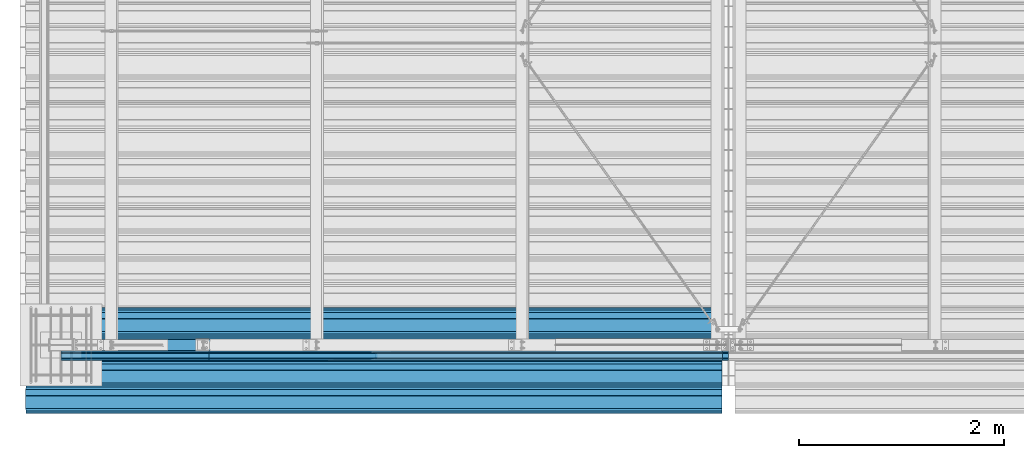
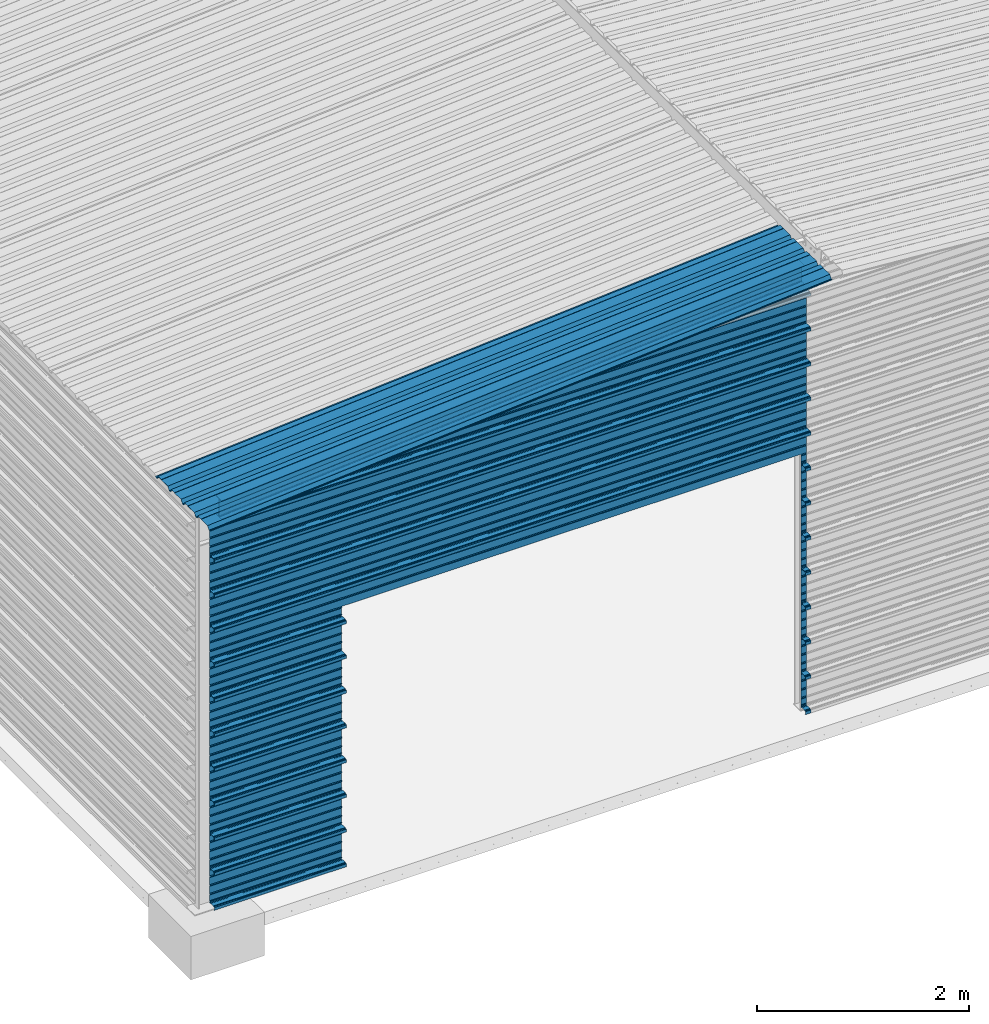
# One storey, part 4 of 70: 14 beams, 14 elements without a shape of their own.
"""IFC2X3 building model written with IfcOpenShell, lengths in millimetres."""

from ifc_helpers import new_model, si_unit, frame, origin_with_axes, origin_2d_with_axis, place, context, subcontext, project, spatial, polyline, i_section, outline, extrude, boolean, clip, halfspace, material, type_object, element, aggregate, save


model = new_model("IFC2X3")

# Units and contexts
model_context = context("Model", 3, precision=1e-05, world=origin_with_axes())
body_context = subcontext(model_context, "Body", "Model", "MODEL_VIEW")
ifc_project = project(units=[si_unit("LENGTHUNIT", "METRE", prefix="MILLI"), si_unit("AREAUNIT", "SQUARE_METRE"), si_unit("VOLUMEUNIT", "CUBIC_METRE"), si_unit("MASSUNIT", "GRAM", prefix="KILO"), si_unit("TIMEUNIT", "SECOND"), si_unit("PLANEANGLEUNIT", "RADIAN"), si_unit("SOLIDANGLEUNIT", "STERADIAN"), si_unit("THERMODYNAMICTEMPERATUREUNIT", "DEGREE_CELSIUS"), si_unit("LUMINOUSINTENSITYUNIT", "LUMEN")], contexts=[model_context])

# Site, building, storey
site_placement = place(None, origin_with_axes())
site = spatial("IfcSite", under=ifc_project, at=site_placement, CompositionType="ELEMENT")
building_placement = place(site_placement, origin_with_axes())
building = spatial("IfcBuilding", under=site, at=building_placement, Name="Undefined", CompositionType="ELEMENT")
storey_placement = place(building_placement, origin_with_axes())
storey = spatial("IfcBuildingStorey", under=building, at=storey_placement, Name="Undefined", CompositionType="ELEMENT", Elevation=0.0)

# Assembly, beam
assembly_1_placement = place(storey_placement, origin_with_axes())
assembly_1 = element("IfcElementAssembly", 1, at=assembly_1_placement, inside=storey, Name="Steel Assembly", AssemblyPlace="NOTDEFINED", PredefinedType="RIGID_FRAME")
ifc_material = material(Name="STEEL/S235JR")
beam_type_1 = type_object("IfcBeamType", Name="4.40", PredefinedType="NOTDEFINED")
beam_1_placement = place(assembly_1_placement, frame((6436.39248868039, -150.0, 5336.31760454388), z_axis=(0.0766964990376782, 0.0, -0.997054485489817), x_axis=(-0.997054485489818, 0.0, -0.0766964990376602)))
beam_1 = element("IfcBeam", 2, at=beam_1_placement, type_object=beam_type_1, material=ifc_material, ObjectType="4.40", context=body_context, shape_type="SweptSolid", body=[
    extrude(outline(polyline([(509.415161132813, 19.5000000011705), (490.584838867188, 19.5000000011705), (468.084838867188, -20.4999999988113), (406.585784912109, -20.4999999988113), (404.585784912109, -18.4999999988122), (345.414215087891, -18.4999999988122), (343.414215087891, -20.4999999988113), (281.915161132813, -20.4999999988113), (259.415161132813, 19.5000000011705), (240.584854125977, 19.5000000011705), (218.084854125977, -20.4999999988113), (156.585784912109, -20.4999999988113), (154.585784912109, -18.4999999988122), (95.4142150878906, -18.4999999988122), (93.4142150878906, -20.4999999988113), (31.9151515960693, -20.4999999988113), (9.41515254974365, 19.5000000011705), (-9.41515254974365, 19.5000000011705), (-31.9151515960693, -20.4999999988113), (-93.4142150878906, -20.4999999988113), (-95.4142150878906, -18.4999999988122), (-154.585784912109, -18.4999999988122), (-156.585784912109, -20.4999999988113), (-218.084854125977, -20.4999999988113), (-240.584854125977, 19.5000000011705), (-259.415161132813, 19.5000000011705), (-281.915161132813, -20.4999999988113), (-343.414215087891, -20.4999999988113), (-345.414215087891, -18.4999999988122), (-404.585784912109, -18.4999999988122), (-406.585784912109, -20.4999999988113), (-468.084838867188, -20.4999999988113), (-490.584838867188, 19.5000000011705), (-509.415161132813, 19.5000000011705), (-516.482360839844, 6.9361057293263), (-517.353942871094, 7.42636680720625), (-510.0, 20.5000000011705), (-490.0, 20.5000000011705), (-467.5, -19.4999999988122), (-407.0, -19.4999999988122), (-405.0, -17.4999999988131), (-345.0, -17.4999999988131), (-343.0, -19.4999999988122), (-282.5, -19.4999999988122), (-260.0, 20.5000000011705), (-240.0, 20.5000000011705), (-217.5, -19.4999999988122), (-157.0, -19.4999999988122), (-155.0, -17.4999999988131), (-95.0, -17.4999999988131), (-93.0, -19.4999999988122), (-32.5, -19.4999999988122), (-10.0, 20.5000000011705), (10.0, 20.5000000011705), (32.5, -19.4999999988122), (93.0, -19.4999999988122), (95.0, -17.4999999988131), (155.0, -17.4999999988131), (157.0, -19.4999999988122), (217.5, -19.4999999988122), (240.0, 20.5000000011705), (260.0, 20.5000000011705), (282.5, -19.4999999988122), (343.0, -19.4999999988122), (345.0, -17.4999999988131), (405.0, -17.4999999988131), (407.0, -19.4999999988122), (467.5, -19.4999999988122), (490.0, 20.5000000011705), (510.0, 20.5000000011705), (517.353942871094, 7.42636680720625), (516.482360839844, 6.9361057293263), (509.415161132813, 19.5000000011705)])), frame((6799.99999999733, 2.8421709430404e-14, 0.0), z_axis=(-1.0, 0.0, 0.0), x_axis=(0.0, -1.0, 0.0)), (0.0, 0.0, 1.0), 6800.0),
])
aggregate(assembly_1, [beam_1])

assembly_2_placement = place(storey_placement, origin_with_axes())
assembly_2 = element("IfcElementAssembly", 3, at=assembly_2_placement, inside=storey, Name="Steel Assembly", AssemblyPlace="NOTDEFINED", PredefinedType="RIGID_FRAME")
beam_type_2 = type_object("IfcBeamType", Name="400", PredefinedType="NOTDEFINED")
beam_2_placement = place(assembly_2_placement, frame((6500.0, -105.5, 4618.25), z_axis=(0.0, -1.0, 0.0), x_axis=(-1.0, 0.0, 0.0)))
beam_2 = element("IfcBeam", 4, at=beam_2_placement, type_object=beam_type_2, material=ifc_material, ObjectType="400", context=body_context, shape_type="Clipping", body=[
    clip(extrude(outline(polyline([(218.25, -24.994083404541), (214.25, -31.8999996185303), (214.25, -45.5), (199.75, -45.5), (194.25, -42.5), (188.75, -45.5), (124.25, -45.5), (114.25, -41.5), (104.25, -45.5), (24.25, -45.5), (14.25, -41.5), (4.25, -45.5), (-75.75, -45.5), (-85.75, -41.5), (-95.75, -45.5), (-160.25, -45.5), (-165.75, -42.5), (-171.25, -45.5), (-185.75, -45.5), (-185.75, -30.711540222168), (-181.75, -23.8111782073975), (-181.75, 23.311637878418), (-185.75, 30.2119998931885), (-185.75, 44.5), (-217.25, 44.5), (-217.25, 34.7999992370605), (-218.25, 34.7999992370605), (-218.25, 45.5), (-184.75, 45.5), (-184.75, 30.480884552002), (-180.75, 23.5805225372314), (-180.75, -24.0800628662109), (-184.75, -30.9804248809814), (-184.75, -44.5), (-171.504989624023, -44.5), (-165.75, -41.360912322998), (-159.995010375977, -44.5), (-95.9425811767578, -44.5), (-85.75, -40.422966003418), (-75.5574188232422, -44.5), (4.05741739273071, -44.5), (14.25, -40.422966003418), (24.4425830841064, -44.5), (104.057418823242, -44.5), (114.25, -40.422966003418), (124.442581176758, -44.5), (188.495010375977, -44.5), (194.25, -41.360912322998), (200.004989624023, -44.5), (213.25, -44.5), (213.25, -31.6313018798828), (217.25, -24.7253856658936), (217.25, 21.7253856658936), (213.25, 28.6313018798828), (213.25, 42.0), (187.25, 42.0), (187.25, 32.5499992370605), (186.25, 32.5499992370605), (186.25, 43.0), (214.25, 43.0), (214.25, 28.8999996185303), (218.25, 21.994083404541), (218.25, -24.994083404541)])), frame((6500.0, 0.0, 0.0), z_axis=(-1.0, 0.0, 0.0), x_axis=(0.0, -1.0, 0.0)), (0.0, 0.0, 1.0), 6500.0), halfspace(frame((6500.0, 18.2500010030071, -45.0), z_axis=(0.0766964990376779, -0.997054485489817, 0.0), x_axis=(-0.997054485489817, -0.0766964990376779, 0.0)), False)),
])
aggregate(assembly_2, [beam_2])

assembly_3_placement = place(storey_placement, origin_with_axes())
assembly_3 = element("IfcElementAssembly", 5, at=assembly_3_placement, inside=storey, Name="Steel Assembly", AssemblyPlace="NOTDEFINED", PredefinedType="RIGID_FRAME")
beam_3_placement = place(assembly_3_placement, frame((6500.0, -105.5, 4218.25), z_axis=(0.0, -1.0, 0.0), x_axis=(-1.0, 0.0, 0.0)))
beam_3 = element("IfcBeam", 6, at=beam_3_placement, type_object=beam_type_2, material=ifc_material, ObjectType="400", context=body_context, shape_type="SweptSolid", body=[
    extrude(outline(polyline([(218.25, -24.994083404541), (214.25, -31.8999996185303), (214.25, -45.5), (199.75, -45.5), (194.25, -42.5), (188.75, -45.5), (124.25, -45.5), (114.25, -41.5), (104.25, -45.5), (24.25, -45.5), (14.25, -41.5), (4.25, -45.5), (-75.75, -45.5), (-85.75, -41.5), (-95.75, -45.5), (-160.25, -45.5), (-165.75, -42.5), (-171.25, -45.5), (-185.75, -45.5), (-185.75, -30.711540222168), (-181.75, -23.8111782073975), (-181.75, 23.311637878418), (-185.75, 30.2119998931885), (-185.75, 44.5), (-217.25, 44.5), (-217.25, 34.7999992370605), (-218.25, 34.7999992370605), (-218.25, 45.5), (-184.75, 45.5), (-184.75, 30.480884552002), (-180.75, 23.5805225372314), (-180.75, -24.0800628662109), (-184.75, -30.9804248809814), (-184.75, -44.5), (-171.504989624023, -44.5), (-165.75, -41.360912322998), (-159.995010375977, -44.5), (-95.9425811767578, -44.5), (-85.75, -40.422966003418), (-75.5574188232422, -44.5), (4.05741739273071, -44.5), (14.25, -40.422966003418), (24.4425830841064, -44.5), (104.057418823242, -44.5), (114.25, -40.422966003418), (124.442581176758, -44.5), (188.495010375977, -44.5), (194.25, -41.360912322998), (200.004989624023, -44.5), (213.25, -44.5), (213.25, -31.6313018798828), (217.25, -24.7253856658936), (217.25, 21.7253856658936), (213.25, 28.6313018798828), (213.25, 42.0), (187.25, 42.0), (187.25, 32.5499992370605), (186.25, 32.5499992370605), (186.25, 43.0), (214.25, 43.0), (214.25, 28.8999996185303), (218.25, 21.994083404541), (218.25, -24.994083404541)])), frame((6500.0, 0.0, 0.0), z_axis=(-1.0, 0.0, 0.0), x_axis=(0.0, -1.0, 0.0)), (0.0, 0.0, 1.0), 6500.0),
])
aggregate(assembly_3, [beam_3])

assembly_4_placement = place(storey_placement, origin_with_axes())
assembly_4 = element("IfcElementAssembly", 7, at=assembly_4_placement, inside=storey, Name="Steel Assembly", AssemblyPlace="NOTDEFINED", PredefinedType="RIGID_FRAME")
beam_4_placement = place(assembly_4_placement, frame((6500.0, -105.5, 3818.25), z_axis=(0.0, -1.0, 0.0), x_axis=(-1.0, 0.0, 0.0)))
beam_4 = element("IfcBeam", 8, at=beam_4_placement, type_object=beam_type_2, material=ifc_material, ObjectType="400", context=body_context, shape_type="SweptSolid", body=[
    extrude(outline(polyline([(218.25, -24.994083404541), (214.25, -31.8999996185303), (214.25, -45.5), (199.75, -45.5), (194.25, -42.5), (188.75, -45.5), (124.25, -45.5), (114.25, -41.5), (104.25, -45.5), (24.25, -45.5), (14.25, -41.5), (4.25, -45.5), (-75.75, -45.5), (-85.75, -41.5), (-95.75, -45.5), (-160.25, -45.5), (-165.75, -42.5), (-171.25, -45.5), (-185.75, -45.5), (-185.75, -30.711540222168), (-181.75, -23.8111782073975), (-181.75, 23.311637878418), (-185.75, 30.2119998931885), (-185.75, 44.5), (-217.25, 44.5), (-217.25, 34.7999992370605), (-218.25, 34.7999992370605), (-218.25, 45.5), (-184.75, 45.5), (-184.75, 30.480884552002), (-180.75, 23.5805225372314), (-180.75, -24.0800628662109), (-184.75, -30.9804248809814), (-184.75, -44.5), (-171.504989624023, -44.5), (-165.75, -41.360912322998), (-159.995010375977, -44.5), (-95.9425811767578, -44.5), (-85.75, -40.422966003418), (-75.5574188232422, -44.5), (4.05741739273071, -44.5), (14.25, -40.422966003418), (24.4425830841064, -44.5), (104.057418823242, -44.5), (114.25, -40.422966003418), (124.442581176758, -44.5), (188.495010375977, -44.5), (194.25, -41.360912322998), (200.004989624023, -44.5), (213.25, -44.5), (213.25, -31.6313018798828), (217.25, -24.7253856658936), (217.25, 21.7253856658936), (213.25, 28.6313018798828), (213.25, 42.0), (187.25, 42.0), (187.25, 32.5499992370605), (186.25, 32.5499992370605), (186.25, 43.0), (214.25, 43.0), (214.25, 28.8999996185303), (218.25, 21.994083404541), (218.25, -24.994083404541)])), frame((6500.0, 0.0, 0.0), z_axis=(-1.0, 0.0, 0.0), x_axis=(0.0, -1.0, 0.0)), (0.0, 0.0, 1.0), 6500.0),
])
aggregate(assembly_4, [beam_4])

assembly_5_placement = place(storey_placement, origin_with_axes())
assembly_5 = element("IfcElementAssembly", 9, at=assembly_5_placement, inside=storey, Name="Steel Assembly", AssemblyPlace="NOTDEFINED", PredefinedType="RIGID_FRAME")
beam_5_placement = place(assembly_5_placement, frame((6500.0, -105.5, 3418.25), z_axis=(0.0, -1.0, 0.0), x_axis=(-1.0, 0.0, 0.0)))
beam_5 = element("IfcBeam", 10, at=beam_5_placement, type_object=beam_type_2, material=ifc_material, ObjectType="400", context=body_context, shape_type="SweptSolid", body=[
    extrude(outline(polyline([(218.25, -24.994083404541), (214.25, -31.8999996185303), (214.25, -45.5), (199.75, -45.5), (194.25, -42.5), (188.75, -45.5), (124.25, -45.5), (114.25, -41.5), (104.25, -45.5), (24.25, -45.5), (14.25, -41.5), (4.25, -45.5), (-75.75, -45.5), (-85.75, -41.5), (-95.75, -45.5), (-160.25, -45.5), (-165.75, -42.5), (-171.25, -45.5), (-185.75, -45.5), (-185.75, -30.711540222168), (-181.75, -23.8111782073975), (-181.75, 23.311637878418), (-185.75, 30.2119998931885), (-185.75, 44.5), (-217.25, 44.5), (-217.25, 34.7999992370605), (-218.25, 34.7999992370605), (-218.25, 45.5), (-184.75, 45.5), (-184.75, 30.480884552002), (-180.75, 23.5805225372314), (-180.75, -24.0800628662109), (-184.75, -30.9804248809814), (-184.75, -44.5), (-171.504989624023, -44.5), (-165.75, -41.360912322998), (-159.995010375977, -44.5), (-95.9425811767578, -44.5), (-85.75, -40.422966003418), (-75.5574188232422, -44.5), (4.05741739273071, -44.5), (14.25, -40.422966003418), (24.4425830841064, -44.5), (104.057418823242, -44.5), (114.25, -40.422966003418), (124.442581176758, -44.5), (188.495010375977, -44.5), (194.25, -41.360912322998), (200.004989624023, -44.5), (213.25, -44.5), (213.25, -31.6313018798828), (217.25, -24.7253856658936), (217.25, 21.7253856658936), (213.25, 28.6313018798828), (213.25, 42.0), (187.25, 42.0), (187.25, 32.5499992370605), (186.25, 32.5499992370605), (186.25, 43.0), (214.25, 43.0), (214.25, 28.8999996185303), (218.25, 21.994083404541), (218.25, -24.994083404541)])), frame((6500.0, 0.0, 0.0), z_axis=(-1.0, 0.0, 0.0), x_axis=(0.0, -1.0, 0.0)), (0.0, 0.0, 1.0), 6500.0),
])
aggregate(assembly_5, [beam_5])

assembly_6_placement = place(storey_placement, origin_with_axes())
assembly_6 = element("IfcElementAssembly", 11, at=assembly_6_placement, inside=storey, Name="Steel Assembly", AssemblyPlace="NOTDEFINED", PredefinedType="RIGID_FRAME")
beam_6_placement = place(assembly_6_placement, frame((6500.0, -105.5, 3018.25), z_axis=(0.0, -1.0, 0.0), x_axis=(-1.0, 0.0, 0.0)))
beam_6 = element("IfcBeam", 12, at=beam_6_placement, type_object=beam_type_2, material=ifc_material, ObjectType="400", context=body_context, shape_type="CSG", body=[
    boolean("DIFFERENCE", extrude(outline(polyline([(218.25, -24.994083404541), (214.25, -31.8999996185303), (214.25, -45.5), (199.75, -45.5), (194.25, -42.5), (188.75, -45.5), (124.25, -45.5), (114.25, -41.5), (104.25, -45.5), (24.25, -45.5), (14.25, -41.5), (4.25, -45.5), (-75.75, -45.5), (-85.75, -41.5), (-95.75, -45.5), (-160.25, -45.5), (-165.75, -42.5), (-171.25, -45.5), (-185.75, -45.5), (-185.75, -30.711540222168), (-181.75, -23.8111782073975), (-181.75, 23.311637878418), (-185.75, 30.2119998931885), (-185.75, 44.5), (-217.25, 44.5), (-217.25, 34.7999992370605), (-218.25, 34.7999992370605), (-218.25, 45.5), (-184.75, 45.5), (-184.75, 30.480884552002), (-180.75, 23.5805225372314), (-180.75, -24.0800628662109), (-184.75, -30.9804248809814), (-184.75, -44.5), (-171.504989624023, -44.5), (-165.75, -41.360912322998), (-159.995010375977, -44.5), (-95.9425811767578, -44.5), (-85.75, -40.422966003418), (-75.5574188232422, -44.5), (4.05741739273071, -44.5), (14.25, -40.422966003418), (24.4425830841064, -44.5), (104.057418823242, -44.5), (114.25, -40.422966003418), (124.442581176758, -44.5), (188.495010375977, -44.5), (194.25, -41.360912322998), (200.004989624023, -44.5), (213.25, -44.5), (213.25, -31.6313018798828), (217.25, -24.7253856658936), (217.25, 21.7253856658936), (213.25, 28.6313018798828), (213.25, 42.0), (187.25, 42.0), (187.25, 32.5499992370605), (186.25, 32.5499992370605), (186.25, 43.0), (214.25, 43.0), (214.25, 28.8999996185303), (218.25, 21.994083404541), (218.25, -24.994083404541)])), frame((6500.0, 0.0, 0.0), z_axis=(-1.0, 0.0, 0.0), x_axis=(0.0, -1.0, 0.0)), (0.0, 0.0, 1.0), 6500.0), extrude(outline(polyline([(0.0, 0.0), (5001.0, 0.0), (5001.0, 2943.0), (0.0, 2943.0), (0.0, 0.0)])), frame((5061.0, 3018.25, -48.0), z_axis=(0.0, 0.0, 1.0), x_axis=(-1.0, 0.0, 0.0)), (0.0, 0.0, 1.0), 96.0)),
])
aggregate(assembly_6, [beam_6])

assembly_7_placement = place(storey_placement, origin_with_axes())
assembly_7 = element("IfcElementAssembly", 13, at=assembly_7_placement, inside=storey, Name="Steel Assembly", AssemblyPlace="NOTDEFINED", PredefinedType="RIGID_FRAME")
beam_7_placement = place(assembly_7_placement, frame((6500.0, -105.5, 2618.25), z_axis=(0.0, -1.0, 0.0), x_axis=(-1.0, 0.0, 0.0)))
beam_7 = element("IfcBeam", 14, at=beam_7_placement, type_object=beam_type_2, material=ifc_material, ObjectType="400", context=body_context, shape_type="CSG", body=[
    boolean("DIFFERENCE", extrude(outline(polyline([(218.25, -24.994083404541), (214.25, -31.8999996185303), (214.25, -45.5), (199.75, -45.5), (194.25, -42.5), (188.75, -45.5), (124.25, -45.5), (114.25, -41.5), (104.25, -45.5), (24.25, -45.5), (14.25, -41.5), (4.25, -45.5), (-75.75, -45.5), (-85.75, -41.5), (-95.75, -45.5), (-160.25, -45.5), (-165.75, -42.5), (-171.25, -45.5), (-185.75, -45.5), (-185.75, -30.711540222168), (-181.75, -23.8111782073975), (-181.75, 23.311637878418), (-185.75, 30.2119998931885), (-185.75, 44.5), (-217.25, 44.5), (-217.25, 34.7999992370605), (-218.25, 34.7999992370605), (-218.25, 45.5), (-184.75, 45.5), (-184.75, 30.480884552002), (-180.75, 23.5805225372314), (-180.75, -24.0800628662109), (-184.75, -30.9804248809814), (-184.75, -44.5), (-171.504989624023, -44.5), (-165.75, -41.360912322998), (-159.995010375977, -44.5), (-95.9425811767578, -44.5), (-85.75, -40.422966003418), (-75.5574188232422, -44.5), (4.05741739273071, -44.5), (14.25, -40.422966003418), (24.4425830841064, -44.5), (104.057418823242, -44.5), (114.25, -40.422966003418), (124.442581176758, -44.5), (188.495010375977, -44.5), (194.25, -41.360912322998), (200.004989624023, -44.5), (213.25, -44.5), (213.25, -31.6313018798828), (217.25, -24.7253856658936), (217.25, 21.7253856658936), (213.25, 28.6313018798828), (213.25, 42.0), (187.25, 42.0), (187.25, 32.5499992370605), (186.25, 32.5499992370605), (186.25, 43.0), (214.25, 43.0), (214.25, 28.8999996185303), (218.25, 21.994083404541), (218.25, -24.994083404541)])), frame((6500.0, 0.0, 0.0), z_axis=(-1.0, 0.0, 0.0), x_axis=(0.0, -1.0, 0.0)), (0.0, 0.0, 1.0), 6500.0), extrude(outline(polyline([(0.0, 0.0), (5001.0, 0.0), (5001.0, 2943.0), (0.0, 2943.0), (0.0, 0.0)])), frame((5061.0, 2618.25, -48.0), z_axis=(0.0, 0.0, 1.0), x_axis=(-1.0, 0.0, 0.0)), (0.0, 0.0, 1.0), 96.0)),
])
aggregate(assembly_7, [beam_7])

assembly_8_placement = place(storey_placement, origin_with_axes())
assembly_8 = element("IfcElementAssembly", 15, at=assembly_8_placement, inside=storey, Name="Steel Assembly", AssemblyPlace="NOTDEFINED", PredefinedType="RIGID_FRAME")
beam_8_placement = place(assembly_8_placement, frame((6500.0, -105.5, 2218.25), z_axis=(0.0, -1.0, 0.0), x_axis=(-1.0, 0.0, 0.0)))
beam_8 = element("IfcBeam", 16, at=beam_8_placement, type_object=beam_type_2, material=ifc_material, ObjectType="400", context=body_context, shape_type="CSG", body=[
    boolean("DIFFERENCE", extrude(outline(polyline([(218.25, -24.994083404541), (214.25, -31.8999996185303), (214.25, -45.5), (199.75, -45.5), (194.25, -42.5), (188.75, -45.5), (124.25, -45.5), (114.25, -41.5), (104.25, -45.5), (24.25, -45.5), (14.25, -41.5), (4.25, -45.5), (-75.75, -45.5), (-85.75, -41.5), (-95.75, -45.5), (-160.25, -45.5), (-165.75, -42.5), (-171.25, -45.5), (-185.75, -45.5), (-185.75, -30.711540222168), (-181.75, -23.8111782073975), (-181.75, 23.311637878418), (-185.75, 30.2119998931885), (-185.75, 44.5), (-217.25, 44.5), (-217.25, 34.7999992370605), (-218.25, 34.7999992370605), (-218.25, 45.5), (-184.75, 45.5), (-184.75, 30.480884552002), (-180.75, 23.5805225372314), (-180.75, -24.0800628662109), (-184.75, -30.9804248809814), (-184.75, -44.5), (-171.504989624023, -44.5), (-165.75, -41.360912322998), (-159.995010375977, -44.5), (-95.9425811767578, -44.5), (-85.75, -40.422966003418), (-75.5574188232422, -44.5), (4.05741739273071, -44.5), (14.25, -40.422966003418), (24.4425830841064, -44.5), (104.057418823242, -44.5), (114.25, -40.422966003418), (124.442581176758, -44.5), (188.495010375977, -44.5), (194.25, -41.360912322998), (200.004989624023, -44.5), (213.25, -44.5), (213.25, -31.6313018798828), (217.25, -24.7253856658936), (217.25, 21.7253856658936), (213.25, 28.6313018798828), (213.25, 42.0), (187.25, 42.0), (187.25, 32.5499992370605), (186.25, 32.5499992370605), (186.25, 43.0), (214.25, 43.0), (214.25, 28.8999996185303), (218.25, 21.994083404541), (218.25, -24.994083404541)])), frame((6500.0, 0.0, 0.0), z_axis=(-1.0, 0.0, 0.0), x_axis=(0.0, -1.0, 0.0)), (0.0, 0.0, 1.0), 6500.0), extrude(outline(polyline([(0.0, 0.0), (5001.0, 0.0), (5001.0, 2943.0), (0.0, 2943.0), (0.0, 0.0)])), frame((5061.0, 2218.25, -48.0), z_axis=(0.0, 0.0, 1.0), x_axis=(-1.0, 0.0, 0.0)), (0.0, 0.0, 1.0), 96.0)),
])
aggregate(assembly_8, [beam_8])

assembly_9_placement = place(storey_placement, origin_with_axes())
assembly_9 = element("IfcElementAssembly", 17, at=assembly_9_placement, inside=storey, Name="Steel Assembly", AssemblyPlace="NOTDEFINED", PredefinedType="RIGID_FRAME")
beam_9_placement = place(assembly_9_placement, frame((6500.0, -105.5, 1818.25), z_axis=(0.0, -1.0, 0.0), x_axis=(-1.0, 0.0, 0.0)))
beam_9 = element("IfcBeam", 18, at=beam_9_placement, type_object=beam_type_2, material=ifc_material, ObjectType="400", context=body_context, shape_type="CSG", body=[
    boolean("DIFFERENCE", extrude(outline(polyline([(218.25, -24.994083404541), (214.25, -31.8999996185303), (214.25, -45.5), (199.75, -45.5), (194.25, -42.5), (188.75, -45.5), (124.25, -45.5), (114.25, -41.5), (104.25, -45.5), (24.25, -45.5), (14.25, -41.5), (4.25, -45.5), (-75.75, -45.5), (-85.75, -41.5), (-95.75, -45.5), (-160.25, -45.5), (-165.75, -42.5), (-171.25, -45.5), (-185.75, -45.5), (-185.75, -30.711540222168), (-181.75, -23.8111782073975), (-181.75, 23.311637878418), (-185.75, 30.2119998931885), (-185.75, 44.5), (-217.25, 44.5), (-217.25, 34.7999992370605), (-218.25, 34.7999992370605), (-218.25, 45.5), (-184.75, 45.5), (-184.75, 30.480884552002), (-180.75, 23.5805225372314), (-180.75, -24.0800628662109), (-184.75, -30.9804248809814), (-184.75, -44.5), (-171.504989624023, -44.5), (-165.75, -41.360912322998), (-159.995010375977, -44.5), (-95.9425811767578, -44.5), (-85.75, -40.422966003418), (-75.5574188232422, -44.5), (4.05741739273071, -44.5), (14.25, -40.422966003418), (24.4425830841064, -44.5), (104.057418823242, -44.5), (114.25, -40.422966003418), (124.442581176758, -44.5), (188.495010375977, -44.5), (194.25, -41.360912322998), (200.004989624023, -44.5), (213.25, -44.5), (213.25, -31.6313018798828), (217.25, -24.7253856658936), (217.25, 21.7253856658936), (213.25, 28.6313018798828), (213.25, 42.0), (187.25, 42.0), (187.25, 32.5499992370605), (186.25, 32.5499992370605), (186.25, 43.0), (214.25, 43.0), (214.25, 28.8999996185303), (218.25, 21.994083404541), (218.25, -24.994083404541)])), frame((6500.0, 0.0, 0.0), z_axis=(-1.0, 0.0, 0.0), x_axis=(0.0, -1.0, 0.0)), (0.0, 0.0, 1.0), 6500.0), extrude(outline(polyline([(0.0, 0.0), (5001.0, 0.0), (5001.0, 2943.0), (0.0, 2943.0), (0.0, 0.0)])), frame((5061.0, 1818.25, -48.0), z_axis=(0.0, 0.0, 1.0), x_axis=(-1.0, 0.0, 0.0)), (0.0, 0.0, 1.0), 96.0)),
])
aggregate(assembly_9, [beam_9])

assembly_10_placement = place(storey_placement, origin_with_axes())
assembly_10 = element("IfcElementAssembly", 19, at=assembly_10_placement, inside=storey, Name="Steel Assembly", AssemblyPlace="NOTDEFINED", PredefinedType="RIGID_FRAME")
beam_10_placement = place(assembly_10_placement, frame((6500.0, -105.5, 1418.25), z_axis=(0.0, -1.0, 0.0), x_axis=(-1.0, 0.0, 0.0)))
beam_10 = element("IfcBeam", 20, at=beam_10_placement, type_object=beam_type_2, material=ifc_material, ObjectType="400", context=body_context, shape_type="CSG", body=[
    boolean("DIFFERENCE", extrude(outline(polyline([(218.25, -24.994083404541), (214.25, -31.8999996185303), (214.25, -45.5), (199.75, -45.5), (194.25, -42.5), (188.75, -45.5), (124.25, -45.5), (114.25, -41.5), (104.25, -45.5), (24.25, -45.5), (14.25, -41.5), (4.25, -45.5), (-75.75, -45.5), (-85.75, -41.5), (-95.75, -45.5), (-160.25, -45.5), (-165.75, -42.5), (-171.25, -45.5), (-185.75, -45.5), (-185.75, -30.711540222168), (-181.75, -23.8111782073975), (-181.75, 23.311637878418), (-185.75, 30.2119998931885), (-185.75, 44.5), (-217.25, 44.5), (-217.25, 34.7999992370605), (-218.25, 34.7999992370605), (-218.25, 45.5), (-184.75, 45.5), (-184.75, 30.480884552002), (-180.75, 23.5805225372314), (-180.75, -24.0800628662109), (-184.75, -30.9804248809814), (-184.75, -44.5), (-171.504989624023, -44.5), (-165.75, -41.360912322998), (-159.995010375977, -44.5), (-95.9425811767578, -44.5), (-85.75, -40.422966003418), (-75.5574188232422, -44.5), (4.05741739273071, -44.5), (14.25, -40.422966003418), (24.4425830841064, -44.5), (104.057418823242, -44.5), (114.25, -40.422966003418), (124.442581176758, -44.5), (188.495010375977, -44.5), (194.25, -41.360912322998), (200.004989624023, -44.5), (213.25, -44.5), (213.25, -31.6313018798828), (217.25, -24.7253856658936), (217.25, 21.7253856658936), (213.25, 28.6313018798828), (213.25, 42.0), (187.25, 42.0), (187.25, 32.5499992370605), (186.25, 32.5499992370605), (186.25, 43.0), (214.25, 43.0), (214.25, 28.8999996185303), (218.25, 21.994083404541), (218.25, -24.994083404541)])), frame((6500.0, 0.0, 0.0), z_axis=(-1.0, 0.0, 0.0), x_axis=(0.0, -1.0, 0.0)), (0.0, 0.0, 1.0), 6500.0), extrude(outline(polyline([(0.0, 0.0), (5001.0, 0.0), (5001.0, 2943.0), (0.0, 2943.0), (0.0, 0.0)])), frame((5061.0, 1418.25, -48.0), z_axis=(0.0, 0.0, 1.0), x_axis=(-1.0, 0.0, 0.0)), (0.0, 0.0, 1.0), 96.0)),
])
aggregate(assembly_10, [beam_10])

assembly_11_placement = place(storey_placement, origin_with_axes())
assembly_11 = element("IfcElementAssembly", 21, at=assembly_11_placement, inside=storey, Name="Steel Assembly", AssemblyPlace="NOTDEFINED", PredefinedType="RIGID_FRAME")
beam_11_placement = place(assembly_11_placement, frame((6500.0, -105.5, 1018.25), z_axis=(0.0, -1.0, 0.0), x_axis=(-1.0, 0.0, 0.0)))
beam_11 = element("IfcBeam", 22, at=beam_11_placement, type_object=beam_type_2, material=ifc_material, ObjectType="400", context=body_context, shape_type="CSG", body=[
    boolean("DIFFERENCE", extrude(outline(polyline([(218.25, -24.994083404541), (214.25, -31.8999996185303), (214.25, -45.5), (199.75, -45.5), (194.25, -42.5), (188.75, -45.5), (124.25, -45.5), (114.25, -41.5), (104.25, -45.5), (24.25, -45.5), (14.25, -41.5), (4.25, -45.5), (-75.75, -45.5), (-85.75, -41.5), (-95.75, -45.5), (-160.25, -45.5), (-165.75, -42.5), (-171.25, -45.5), (-185.75, -45.5), (-185.75, -30.711540222168), (-181.75, -23.8111782073975), (-181.75, 23.311637878418), (-185.75, 30.2119998931885), (-185.75, 44.5), (-217.25, 44.5), (-217.25, 34.7999992370605), (-218.25, 34.7999992370605), (-218.25, 45.5), (-184.75, 45.5), (-184.75, 30.480884552002), (-180.75, 23.5805225372314), (-180.75, -24.0800628662109), (-184.75, -30.9804248809814), (-184.75, -44.5), (-171.504989624023, -44.5), (-165.75, -41.360912322998), (-159.995010375977, -44.5), (-95.9425811767578, -44.5), (-85.75, -40.422966003418), (-75.5574188232422, -44.5), (4.05741739273071, -44.5), (14.25, -40.422966003418), (24.4425830841064, -44.5), (104.057418823242, -44.5), (114.25, -40.422966003418), (124.442581176758, -44.5), (188.495010375977, -44.5), (194.25, -41.360912322998), (200.004989624023, -44.5), (213.25, -44.5), (213.25, -31.6313018798828), (217.25, -24.7253856658936), (217.25, 21.7253856658936), (213.25, 28.6313018798828), (213.25, 42.0), (187.25, 42.0), (187.25, 32.5499992370605), (186.25, 32.5499992370605), (186.25, 43.0), (214.25, 43.0), (214.25, 28.8999996185303), (218.25, 21.994083404541), (218.25, -24.994083404541)])), frame((6500.0, 0.0, 0.0), z_axis=(-1.0, 0.0, 0.0), x_axis=(0.0, -1.0, 0.0)), (0.0, 0.0, 1.0), 6500.0), extrude(outline(polyline([(0.0, 0.0), (5001.0, 0.0), (5001.0, 2943.0), (0.0, 2943.0), (0.0, 0.0)])), frame((5061.0, 1018.25, -48.0), z_axis=(0.0, 0.0, 1.0), x_axis=(-1.0, 0.0, 0.0)), (0.0, 0.0, 1.0), 96.0)),
])
aggregate(assembly_11, [beam_11])

assembly_12_placement = place(storey_placement, origin_with_axes())
assembly_12 = element("IfcElementAssembly", 23, at=assembly_12_placement, inside=storey, Name="Steel Assembly", AssemblyPlace="NOTDEFINED", PredefinedType="RIGID_FRAME")
beam_12_placement = place(assembly_12_placement, frame((6500.0, -105.5, 618.25), z_axis=(0.0, -1.0, 0.0), x_axis=(-1.0, 0.0, 0.0)))
beam_12 = element("IfcBeam", 24, at=beam_12_placement, type_object=beam_type_2, material=ifc_material, ObjectType="400", context=body_context, shape_type="CSG", body=[
    boolean("DIFFERENCE", extrude(outline(polyline([(218.25, -24.994083404541), (214.25, -31.8999996185303), (214.25, -45.5), (199.75, -45.5), (194.25, -42.5), (188.75, -45.5), (124.25, -45.5), (114.25, -41.5), (104.25, -45.5), (24.25, -45.5), (14.25, -41.5), (4.25, -45.5), (-75.75, -45.5), (-85.75, -41.5), (-95.75, -45.5), (-160.25, -45.5), (-165.75, -42.5), (-171.25, -45.5), (-185.75, -45.5), (-185.75, -30.711540222168), (-181.75, -23.8111782073975), (-181.75, 23.311637878418), (-185.75, 30.2119998931885), (-185.75, 44.5), (-217.25, 44.5), (-217.25, 34.7999992370605), (-218.25, 34.7999992370605), (-218.25, 45.5), (-184.75, 45.5), (-184.75, 30.480884552002), (-180.75, 23.5805225372314), (-180.75, -24.0800628662109), (-184.75, -30.9804248809814), (-184.75, -44.5), (-171.504989624023, -44.5), (-165.75, -41.360912322998), (-159.995010375977, -44.5), (-95.9425811767578, -44.5), (-85.75, -40.422966003418), (-75.5574188232422, -44.5), (4.05741739273071, -44.5), (14.25, -40.422966003418), (24.4425830841064, -44.5), (104.057418823242, -44.5), (114.25, -40.422966003418), (124.442581176758, -44.5), (188.495010375977, -44.5), (194.25, -41.360912322998), (200.004989624023, -44.5), (213.25, -44.5), (213.25, -31.6313018798828), (217.25, -24.7253856658936), (217.25, 21.7253856658936), (213.25, 28.6313018798828), (213.25, 42.0), (187.25, 42.0), (187.25, 32.5499992370605), (186.25, 32.5499992370605), (186.25, 43.0), (214.25, 43.0), (214.25, 28.8999996185303), (218.25, 21.994083404541), (218.25, -24.994083404541)])), frame((6500.0, 0.0, 0.0), z_axis=(-1.0, 0.0, 0.0), x_axis=(0.0, -1.0, 0.0)), (0.0, 0.0, 1.0), 6500.0), extrude(outline(polyline([(0.0, 0.0), (5001.0, 0.0), (5001.0, 2943.0), (0.0, 2943.0), (0.0, 0.0)])), frame((5061.0, 618.25, -48.0), z_axis=(0.0, 0.0, 1.0), x_axis=(-1.0, 0.0, 0.0)), (0.0, 0.0, 1.0), 96.0)),
])
aggregate(assembly_12, [beam_12])

assembly_13_placement = place(storey_placement, origin_with_axes())
assembly_13 = element("IfcElementAssembly", 25, at=assembly_13_placement, inside=storey, Name="Steel Assembly", AssemblyPlace="NOTDEFINED", PredefinedType="RIGID_FRAME")
beam_13_placement = place(assembly_13_placement, frame((6500.0, -105.5, 218.25), z_axis=(0.0, -1.0, 0.0), x_axis=(-1.0, 0.0, 0.0)))
beam_13 = element("IfcBeam", 26, at=beam_13_placement, type_object=beam_type_2, material=ifc_material, ObjectType="400", context=body_context, shape_type="CSG", body=[
    boolean("DIFFERENCE", extrude(outline(polyline([(218.25, -24.994083404541), (214.25, -31.8999996185303), (214.25, -45.5), (199.75, -45.5), (194.25, -42.5), (188.75, -45.5), (124.25, -45.5), (114.25, -41.5), (104.25, -45.5), (24.25, -45.5), (14.25, -41.5), (4.25, -45.5), (-75.75, -45.5), (-85.75, -41.5), (-95.75, -45.5), (-160.25, -45.5), (-165.75, -42.5), (-171.25, -45.5), (-185.75, -45.5), (-185.75, -30.711540222168), (-181.75, -23.8111782073975), (-181.75, 23.311637878418), (-185.75, 30.2119998931885), (-185.75, 44.5), (-217.25, 44.5), (-217.25, 34.7999992370605), (-218.25, 34.7999992370605), (-218.25, 45.5), (-184.75, 45.5), (-184.75, 30.480884552002), (-180.75, 23.5805225372314), (-180.75, -24.0800628662109), (-184.75, -30.9804248809814), (-184.75, -44.5), (-171.504989624023, -44.5), (-165.75, -41.360912322998), (-159.995010375977, -44.5), (-95.9425811767578, -44.5), (-85.75, -40.422966003418), (-75.5574188232422, -44.5), (4.05741739273071, -44.5), (14.25, -40.422966003418), (24.4425830841064, -44.5), (104.057418823242, -44.5), (114.25, -40.422966003418), (124.442581176758, -44.5), (188.495010375977, -44.5), (194.25, -41.360912322998), (200.004989624023, -44.5), (213.25, -44.5), (213.25, -31.6313018798828), (217.25, -24.7253856658936), (217.25, 21.7253856658936), (213.25, 28.6313018798828), (213.25, 42.0), (187.25, 42.0), (187.25, 32.5499992370605), (186.25, 32.5499992370605), (186.25, 43.0), (214.25, 43.0), (214.25, 28.8999996185303), (218.25, 21.994083404541), (218.25, -24.994083404541)])), frame((6500.0, 0.0, 0.0), z_axis=(-1.0, 0.0, 0.0), x_axis=(0.0, -1.0, 0.0)), (0.0, 0.0, 1.0), 6500.0), extrude(outline(polyline([(0.0, 0.0), (5001.0, 0.0), (5001.0, 2943.0), (0.0, 2943.0), (0.0, 0.0)])), frame((5061.0, 218.25, -48.0), z_axis=(0.0, 0.0, 1.0), x_axis=(-1.0, 0.0, 0.0)), (0.0, 0.0, 1.0), 96.0)),
])
aggregate(assembly_13, [beam_13])

assembly_14_placement = place(storey_placement, origin_with_axes())
assembly_14 = element("IfcElementAssembly", 27, at=assembly_14_placement, inside=storey, Name="Steel Assembly", AssemblyPlace="NOTDEFINED", PredefinedType="RIGID_FRAME")
beam_type_3 = type_object("IfcBeamType", Name="IPE220", PredefinedType="NOTDEFINED")
beam_14_placement = place(assembly_14_placement, frame((8.43661487722628, 0.0, 4490.32400659478), z_axis=(-0.0766964990376602, 0.0, 0.997054485489818), x_axis=(0.997054485489816, 0.0, 0.0766964990376847)))
beam_14 = element("IfcBeam", 28, at=beam_14_placement, type_object=beam_type_3, material=ifc_material, Name="POUTRE", ObjectType="IPE220", context=body_context, shape_type="Clipping", body=[
    clip(clip(extrude(i_section(OverallWidth=110.0, OverallDepth=220.0, WebThickness=5.900000095, FlangeThickness=9.199999809, FilletRadius=12.0, at=origin_2d_with_axis()), frame((6512.78885803273, 3.63797880709171e-12, 0.0), z_axis=(-1.0, 0.0, 0.0), x_axis=(0.0, -1.0, 0.0)), (0.0, 0.0, 1.0), 6402.94), halfspace(frame((6504.24658470657, 3.63797880709171e-12, 111.150446985645), z_axis=(-0.997054485489817, 0.0, 0.0766964990376713), x_axis=(0.0, -1.0, 0.0)), True)), halfspace(frame((118.475742245822, 3.63797880709171e-12, -110.000000009088), z_axis=(0.997054485489817, 0.0, -0.0766964990376783), x_axis=(0.0, -1.0, 0.0)), True)),
])
aggregate(assembly_14, [beam_14])

save(model, "model.ifc")
